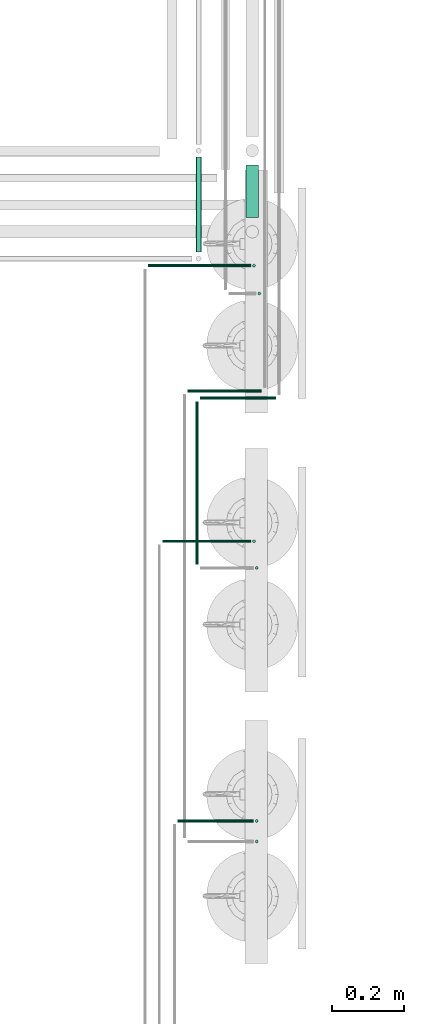
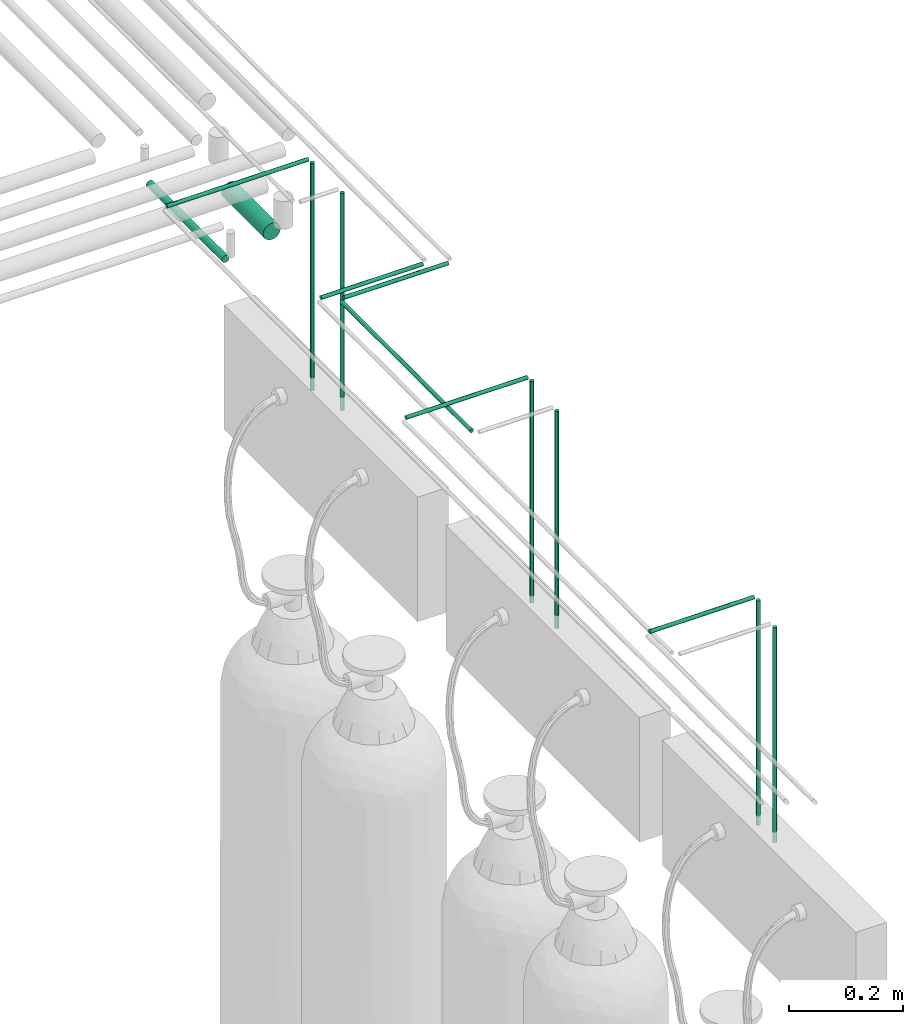
# One storey, part 206 of 331: 14 flow segments.
"""IFC2X3 building model written with IfcOpenShell, lengths in millimetres."""

from ifc_helpers import new_model, entity, si_unit, converted_unit, derived_unit, direction, frame, frame_2d, origin, origin_2d_with_axis, place, context, subcontext, project, spatial, circle, extrude, type_object, element, save


model = new_model("IFC2X3")

# Units and contexts
model_context = context("Model", 3, precision=0.01, world=origin(), true_north=direction((6.12303176911189e-17, 1.0)))
body_context = subcontext(model_context, "Body", "Model", "MODEL_VIEW")
ifc_project = project(units=[si_unit("LENGTHUNIT", "METRE", prefix="MILLI"), si_unit("AREAUNIT", "SQUARE_METRE"), si_unit("VOLUMEUNIT", "CUBIC_METRE"), converted_unit("PLANEANGLEUNIT", "DEGREE", entity("IfcRatioMeasure", 0.0174532925199433), si_unit("PLANEANGLEUNIT", "RADIAN"), dimensions=[0, 0, 0, 0, 0, 0, 0]), si_unit("MASSUNIT", "GRAM", prefix="KILO"), derived_unit("MASSDENSITYUNIT", [(si_unit("MASSUNIT", "GRAM", prefix="KILO"), 1), (si_unit("LENGTHUNIT", "METRE"), -3)]), derived_unit("MOMENTOFINERTIAUNIT", [(si_unit("LENGTHUNIT", "METRE"), 4)]), si_unit("TIMEUNIT", "SECOND"), si_unit("FREQUENCYUNIT", "HERTZ"), si_unit("THERMODYNAMICTEMPERATUREUNIT", "DEGREE_CELSIUS"), derived_unit("THERMALTRANSMITTANCEUNIT", [(si_unit("MASSUNIT", "GRAM", prefix="KILO"), 1), (si_unit("THERMODYNAMICTEMPERATUREUNIT", "KELVIN"), -1), (si_unit("TIMEUNIT", "SECOND"), -3)]), derived_unit("VOLUMETRICFLOWRATEUNIT", [(si_unit("LENGTHUNIT", "METRE"), 3), (si_unit("TIMEUNIT", "SECOND"), -1)]), derived_unit("MASSFLOWRATEUNIT", [(si_unit("MASSUNIT", "GRAM", prefix="KILO"), 1), (si_unit("TIMEUNIT", "SECOND"), -1)]), derived_unit("ROTATIONALFREQUENCYUNIT", [(si_unit("TIMEUNIT", "SECOND"), -1)]), si_unit("ELECTRICCURRENTUNIT", "AMPERE"), si_unit("ELECTRICVOLTAGEUNIT", "VOLT"), si_unit("POWERUNIT", "WATT"), si_unit("FORCEUNIT", "NEWTON", prefix="KILO"), si_unit("ILLUMINANCEUNIT", "LUX"), si_unit("LUMINOUSFLUXUNIT", "LUMEN"), si_unit("LUMINOUSINTENSITYUNIT", "CANDELA"), derived_unit("USERDEFINED", [(si_unit("MASSUNIT", "GRAM", prefix="KILO"), -1), (si_unit("LENGTHUNIT", "METRE"), -2), (si_unit("TIMEUNIT", "SECOND"), 3), (si_unit("LUMINOUSFLUXUNIT", "LUMEN"), 1)]), derived_unit("LINEARVELOCITYUNIT", [(si_unit("LENGTHUNIT", "METRE"), 1), (si_unit("TIMEUNIT", "SECOND"), -1)]), si_unit("PRESSUREUNIT", "PASCAL"), derived_unit("USERDEFINED", [(si_unit("LENGTHUNIT", "METRE"), -2), (si_unit("MASSUNIT", "GRAM", prefix="KILO"), 1), (si_unit("TIMEUNIT", "SECOND"), -2)]), derived_unit("LINEARFORCEUNIT", [(si_unit("MASSUNIT", "GRAM", prefix="KILO"), 1), (si_unit("LENGTHUNIT", "METRE"), 1), (si_unit("TIMEUNIT", "SECOND"), -2), (si_unit("LENGTHUNIT", "METRE"), -1)]), derived_unit("PLANARFORCEUNIT", [(si_unit("MASSUNIT", "GRAM", prefix="KILO"), 1), (si_unit("LENGTHUNIT", "METRE"), 1), (si_unit("TIMEUNIT", "SECOND"), -2), (si_unit("LENGTHUNIT", "METRE"), -2)])], contexts=[model_context])

# Site, building, storey
site_placement = place(None, frame((0.0, -0.00077364408347762, 0.0)))
site = spatial("IfcSite", under=ifc_project, at=site_placement, CompositionType="ELEMENT")
building_placement = place(site_placement, origin())
building = spatial("IfcBuilding", under=site, at=building_placement, CompositionType="ELEMENT")
storey_placement = place(building_placement, origin())
storey = spatial("IfcBuildingStorey", under=building, at=storey_placement, CompositionType="ELEMENT", Elevation=0.0)

# Flow segments
pipe_segment_type = type_object("IfcPipeSegmentType", PredefinedType="NOTDEFINED")
flow_segment_1_placement = place(building_placement, frame((64230.9083446482, -830.130122350307, 2690.90472776408)))
element("IfcFlowSegment", 1, at=flow_segment_1_placement, inside=storey, type_object=pipe_segment_type, context=body_context, shape_type="SweptSolid", body=[
    extrude(circle(Radius=17.5, at=frame_2d((8.66293703438714e-12, 5.41433564649194e-13), x_axis=(1.0, 0.0))), frame((19.0952722359206, 0.0, 19.0952722359157), z_axis=(0.0, 1.0, 0.0), x_axis=(-1.0, 0.0, 0.0)), (0.0, 0.0, 1.0), 146.830921173468),
])
flow_segment_2_placement = place(storey_placement, frame((64090.9083446482, -927.11777764672, 2753.09456209048)))
element("IfcFlowSegment", 2, at=flow_segment_2_placement, inside=storey, type_object=pipe_segment_type, context=body_context, shape_type="SweptSolid", body=[
    extrude(circle(Radius=7.5, at=origin_2d_with_axis()), frame((9.09527223591419, 0.0, 9.09527223591582), z_axis=(0.0, 1.0, 0.0), x_axis=(1.0, 0.0, 0.0)), (0.0, 0.0, 1.0), 265.818576469895),
])
flow_segment_3_placement = place(storey_placement, frame((64104.0036168841, -1340.59527223571, 2919.40472776408)))
element("IfcFlowSegment", 3, at=flow_segment_3_placement, inside=storey, type_object=pipe_segment_type, context=body_context, shape_type="SweptSolid", body=[
    extrude(circle(Radius=4.0, at=frame_2d((-4.06075173486897e-12, 0.0), x_axis=(1.0, 0.0))), frame((0.0, 5.59527223591986, 5.59527223591607), z_axis=(1.0, 0.0, 0.0), x_axis=(0.0, 1.0, 0.0)), (0.0, 0.0, 1.0), 212.000000000047),
])
flow_segment_4_placement = place(storey_placement, frame((64089.4083446482, -1801.0, 2919.40472776408)))
element("IfcFlowSegment", 4, at=flow_segment_4_placement, inside=storey, type_object=pipe_segment_type, context=body_context, shape_type="SweptSolid", body=[
    extrude(circle(Radius=4.0, at=frame_2d((8.66293703438714e-12, 0.0), x_axis=(1.0, 0.0))), frame((5.59527223591499, 0.0, 5.59527223591607), z_axis=(0.0, 1.0, 0.0), x_axis=(-1.0, 0.0, 0.0)), (0.0, 0.0, 1.0), 457.000000000008),
])
flow_segment_5_placement = place(storey_placement, frame((64069.0036168841, -1320.59527223572, 2919.40472776408)))
element("IfcFlowSegment", 5, at=flow_segment_5_placement, inside=storey, type_object=pipe_segment_type, context=body_context, shape_type="SweptSolid", body=[
    extrude(circle(Radius=4.0, at=frame_2d((-4.06075173486897e-12, 0.0), x_axis=(1.0, 0.0))), frame((0.0, 5.59527223591986, 5.59527223591607), z_axis=(1.0, 0.0, 0.0), x_axis=(0.0, 1.0, 0.0)), (0.0, 0.0, 1.0), 207.000000000057),
])
flow_segment_6_placement = place(storey_placement, frame((64264.4083446482, -1048.09527223572, 2450.0)))
element("IfcFlowSegment", 6, at=flow_segment_6_placement, inside=storey, type_object=pipe_segment_type, context=body_context, shape_type="SweptSolid", body=[
    extrude(circle(Radius=4.0, at=frame_2d((0.0, -1.35358391162299e-13), x_axis=(1.0, 0.0))), frame((5.59527223591499, 5.59527223591621, 0.0)), (0.0, 0.0, 1.0), 466.000000000004),
])
flow_segment_7_placement = place(storey_placement, frame((64256.9083446483, -1815.59527223571, 2450.0)))
element("IfcFlowSegment", 7, at=flow_segment_7_placement, inside=storey, type_object=pipe_segment_type, context=body_context, shape_type="SweptSolid", body=[
    extrude(circle(Radius=4.0, at=frame_2d((0.0, -2.70716782324598e-13), x_axis=(1.0, 0.0))), frame((5.59527223591499, 5.59527223591607, 0.0)), (0.0, 0.0, 1.0), 466.000000000003),
])
flow_segment_8_placement = place(storey_placement, frame((64256.9083446483, -2580.59527223572, 2455.0)))
element("IfcFlowSegment", 8, at=flow_segment_8_placement, inside=storey, type_object=pipe_segment_type, context=body_context, shape_type="SweptSolid", body=[
    extrude(circle(Radius=4.0, at=origin_2d_with_axis()), frame((5.59527223591499, 5.59527223591607, 0.0)), (0.0, 0.0, 1.0), 460.999999999999),
])
flow_segment_9_placement = place(storey_placement, frame((63958.8006994404, -970.167411034867, 2941.90472776409)))
element("IfcFlowSegment", 9, at=flow_segment_9_placement, inside=storey, type_object=pipe_segment_type, context=body_context, shape_type="SweptSolid", body=[
    extrude(circle(Radius=4.0, at=frame_2d((-2.84252621440828e-12, 0.0), x_axis=(1.0, 0.0))), frame((0.0, 5.59527223591892, 5.59527223591607), z_axis=(1.0, 0.0, 0.0), x_axis=(0.0, 1.0, 0.0)), (0.0, 0.0, 1.0), 286.999999999978),
])
flow_segment_10_placement = place(storey_placement, frame((63998.8006994404, -1741.24981011329, 2941.90472776409)))
element("IfcFlowSegment", 10, at=flow_segment_10_placement, inside=storey, type_object=pipe_segment_type, context=body_context, shape_type="SweptSolid", body=[
    extrude(circle(Radius=4.0, at=frame_2d((-2.97788460557058e-12, 0.0), x_axis=(1.0, 0.0))), frame((0.0, 5.59527223591851, 5.59527223591607), z_axis=(1.0, 0.0, 0.0), x_axis=(0.0, 1.0, 0.0)), (0.0, 0.0, 1.0), 247.000000000022),
])
flow_segment_11_placement = place(storey_placement, frame((64041.5332475126, -2523.18806035668, 2941.90472776409)))
element("IfcFlowSegment", 11, at=flow_segment_11_placement, inside=storey, type_object=pipe_segment_type, context=body_context, shape_type="SweptSolid", body=[
    extrude(circle(Radius=4.0, at=frame_2d((-2.70716782324598e-12, 0.0), x_axis=(1.0, 0.0))), frame((0.0, 5.59527223591878, 5.59527223591607), z_axis=(1.0, 0.0, 0.0), x_axis=(0.0, 1.0, 0.0)), (0.0, 0.0, 1.0), 212.000000000021),
])
flow_segment_12_placement = place(storey_placement, frame((64256.9379752767, -2523.18806035668, 2457.5)))
element("IfcFlowSegment", 12, at=flow_segment_12_placement, inside=storey, type_object=pipe_segment_type, context=body_context, shape_type="SweptSolid", body=[
    extrude(circle(Radius=4.0, at=origin_2d_with_axis()), frame((5.59527223591499, 5.59527223591607, 0.0)), (0.0, 0.0, 1.0), 481.000000000004),
])
flow_segment_13_placement = place(storey_placement, frame((64249.2054272045, -1741.24981011329, 2462.5)))
element("IfcFlowSegment", 13, at=flow_segment_13_placement, inside=storey, type_object=pipe_segment_type, context=body_context, shape_type="SweptSolid", body=[
    extrude(circle(Radius=4.0, at=origin_2d_with_axis()), frame((5.59527223591499, 5.5952722359158, 0.0)), (0.0, 0.0, 1.0), 476.000000000004),
])
flow_segment_14_placement = place(storey_placement, frame((64249.2054272045, -970.167411034867, 2450.0)))
element("IfcFlowSegment", 14, at=flow_segment_14_placement, inside=storey, type_object=pipe_segment_type, context=body_context, shape_type="SweptSolid", body=[
    extrude(circle(Radius=4.0, at=origin_2d_with_axis()), frame((5.59527223591499, 5.59527223591607, 0.0)), (0.0, 0.0, 1.0), 488.5),
])

save(model, "model.ifc")
